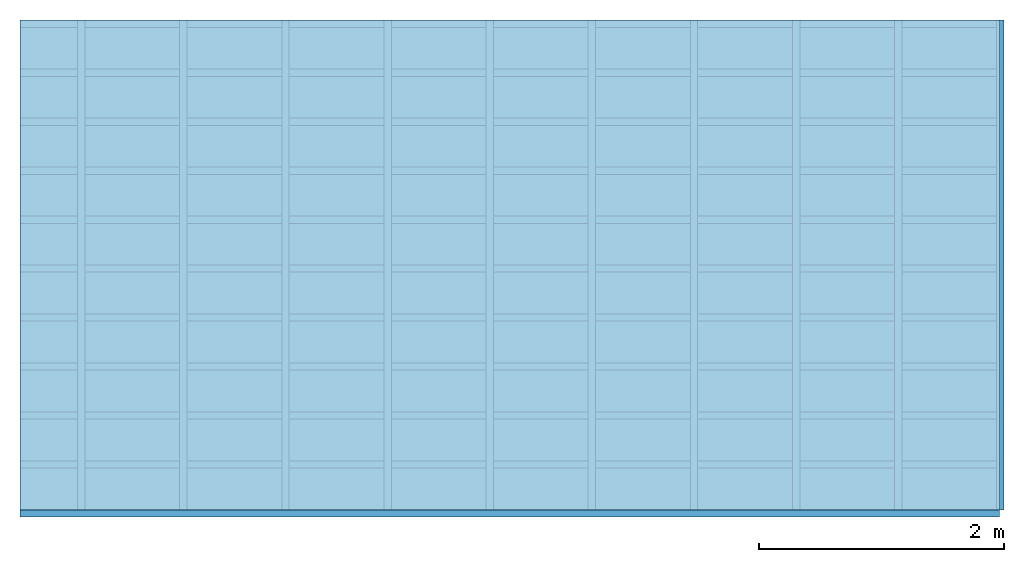
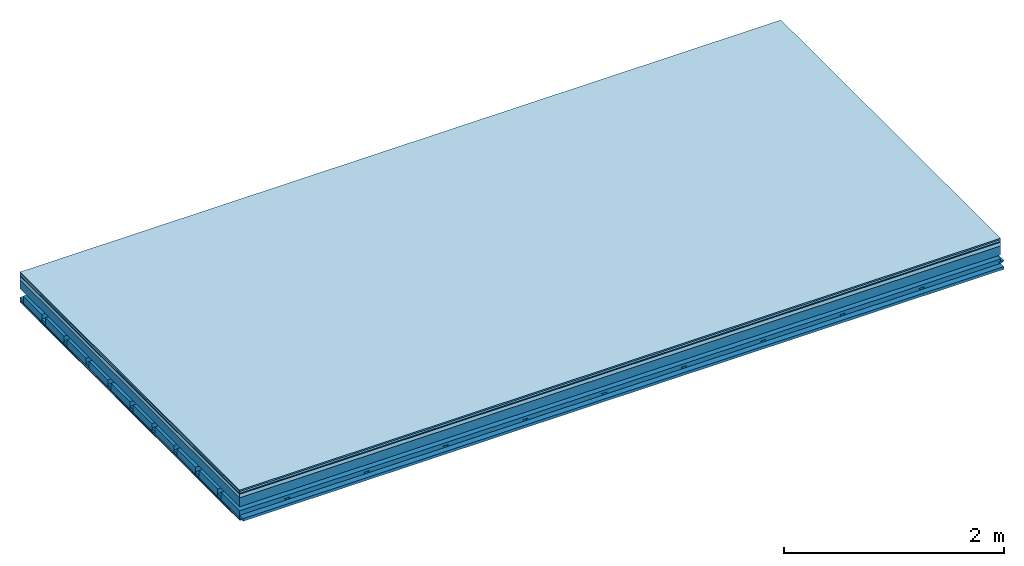
# One storey: 7 plates, 4 members, 1 element without a shape of its own.
"""IFC4 building model written with IfcOpenShell, lengths in metres."""

from ifc_helpers import new_model, si_unit, derived_unit, direction, frame, frame_2d, origin, origin_with_axes, place, context, project, spatial, polyline, rectangle, outline, extrude, material, layer, layer_set, type_object, element, aggregate, save


model = new_model("IFC4")

# Units and contexts
plan_context = context("Plan", 3, precision=1e-05, world=origin(), true_north=direction((0.0, 1.0)))
model_context = context("Model", 3, precision=1e-05, world=origin(), true_north=direction((0.0, 1.0)))
ifc_project = project(units=[si_unit("LENGTHUNIT", "METRE"), derived_unit("SOUNDPRESSUREUNIT", [(si_unit("PRESSUREUNIT", "PASCAL", prefix="MICRO"), 0)]), si_unit("ENERGYUNIT", "JOULE", prefix="MEGA"), si_unit("MASSUNIT", "GRAM", prefix="KILO"), derived_unit("THERMALTRANSMITTANCEUNIT", [(si_unit("POWERUNIT", "WATT"), 1), (si_unit("AREAUNIT", "SQUARE_METRE"), -1), (si_unit("THERMODYNAMICTEMPERATUREUNIT", "KELVIN"), -1)]), derived_unit("AREADENSITYUNIT", [(si_unit("MASSUNIT", "GRAM", prefix="KILO"), 1), (si_unit("AREAUNIT", "SQUARE_METRE"), -1)]), derived_unit("USERDEFINED", [(si_unit("ENERGYUNIT", "JOULE", prefix="MEGA"), 1), (si_unit("AREAUNIT", "SQUARE_METRE"), -1)])], contexts=[plan_context, model_context])

# Site, building, storey
site = spatial("IfcSite", under=ifc_project)
building_placement = place(None, origin())
building = spatial("IfcBuilding", under=site, at=building_placement)
storey_placement = place(building_placement, origin())
storey = spatial("IfcBuildingStorey", under=building, at=storey_placement)

# Slab, members, plates
ifc_material_1 = material(Category="11.013")
ifc_layer_1 = layer(ifc_material_1, 0.015, Name="Flooring")
ifc_material_2 = material(Category="03.007")
ifc_layer_2 = layer(ifc_material_2, 0.02, Name="On-material")
ifc_material_3 = material(Name="Wood fiber generic product", Category="10.009")
ifc_layer_3 = layer(ifc_material_3, 0.01, Name="Impact sound insulation")
ifc_material_4 = material(Name="Concrete panels", Category="02.007")
ifc_layer_4 = layer(ifc_material_4, 0.04, Name="on Supporting structure")
ifc_material_5 = material(Name="no composite action")
ifc_layer_5 = layer(ifc_material_5, 0.0, Name="Bond")
ifc_layer_6 = layer(None, 0.1, Name="Supporting structure")
ifc_layer_7 = layer(ifc_material_5, 0.0, Name="Bond")
ifc_layer_8 = layer(None, 0.095, Name="Coupling")
ifc_layer_9 = layer(None, 0.03, Name="Battens / profiles")
ifc_material_6 = material(Name="Plasterboard type A", Category="03.008")
ifc_layer_10 = layer(ifc_material_6, 0.0125, Name="Ceiling covering 1st layer")
ifc_layer_11 = layer(ifc_material_6, 0.0125, Name="Ceiling covering layer 2")
ifc_material_7 = material(Category="04.001")
ifc_layer_12 = layer(ifc_material_7, 0.003, Name="Surface / treatment")
ifc_layer_set = layer_set([ifc_layer_1, ifc_layer_2, ifc_layer_3, ifc_layer_4, ifc_layer_5, ifc_layer_6, ifc_layer_7, ifc_layer_8, ifc_layer_9, ifc_layer_10, ifc_layer_11, ifc_layer_12])
slab_type = type_object("IfcSlabType", Name="A2131", PredefinedType="NOTDEFINED", material=ifc_layer_set)
slab_placement = place(None, frame((0.0, 0.0, 0.0), z_axis=(0.0, 0.0, -1.0), x_axis=(1.0, 0.0, 0.0)))
slab = element("IfcSlab", 1, at=slab_placement, inside=storey, type_object=slab_type, material=ifc_layer_set, Name="Slab #1")
ifc_material_8 = material(Name="Solid timber panel")
member_1_placement = place(slab_placement, origin())
member_1 = element("IfcMember", 2, at=member_1_placement, material=ifc_material_8, Name="Supporting structure", context=plan_context, shape_type="SweptSolid", body=[
    extrude(rectangle(XDim=1.0, YDim=0.1, at=frame_2d((0.5, 0.05), x_axis=(1.0, 0.0))), frame((0.0, 4.0, 0.085), z_axis=(0.0, -1.0, 0.0), x_axis=(1.0, 0.0, 0.0)), (0.0, 0.0, 1.0), 4.0),
    extrude(rectangle(XDim=1.0, YDim=0.1, at=frame_2d((0.5, 0.05), x_axis=(1.0, 0.0))), frame((1.0, 4.0, 0.085), z_axis=(0.0, -1.0, 0.0), x_axis=(1.0, 0.0, 0.0)), (0.0, 0.0, 1.0), 4.0),
    extrude(rectangle(XDim=1.0, YDim=0.1, at=frame_2d((0.5, 0.05), x_axis=(1.0, 0.0))), frame((2.0, 4.0, 0.085), z_axis=(0.0, -1.0, 0.0), x_axis=(1.0, 0.0, 0.0)), (0.0, 0.0, 1.0), 4.0),
    extrude(rectangle(XDim=1.0, YDim=0.1, at=frame_2d((0.5, 0.05), x_axis=(1.0, 0.0))), frame((3.0, 4.0, 0.085), z_axis=(0.0, -1.0, 0.0), x_axis=(1.0, 0.0, 0.0)), (0.0, 0.0, 1.0), 4.0),
    extrude(rectangle(XDim=1.0, YDim=0.1, at=frame_2d((0.5, 0.05), x_axis=(1.0, 0.0))), frame((4.0, 4.0, 0.085), z_axis=(0.0, -1.0, 0.0), x_axis=(1.0, 0.0, 0.0)), (0.0, 0.0, 1.0), 4.0),
    extrude(rectangle(XDim=1.0, YDim=0.1, at=frame_2d((0.5, 0.05), x_axis=(1.0, 0.0))), frame((5.0, 4.0, 0.085), z_axis=(0.0, -1.0, 0.0), x_axis=(1.0, 0.0, 0.0)), (0.0, 0.0, 1.0), 4.0),
    extrude(rectangle(XDim=1.0, YDim=0.1, at=frame_2d((0.5, 0.05), x_axis=(1.0, 0.0))), frame((6.0, 4.0, 0.085), z_axis=(0.0, -1.0, 0.0), x_axis=(1.0, 0.0, 0.0)), (0.0, 0.0, 1.0), 4.0),
    extrude(rectangle(XDim=1.0, YDim=0.1, at=frame_2d((0.5, 0.05), x_axis=(1.0, 0.0))), frame((7.0, 4.0, 0.085), z_axis=(0.0, -1.0, 0.0), x_axis=(1.0, 0.0, 0.0)), (0.0, 0.0, 1.0), 4.0),
])
ifc_material_9 = material()
member_2_placement = place(slab_placement, origin())
member_2 = element("IfcMember", 3, at=member_2_placement, material=ifc_material_9, Name="Coupling", context=plan_context, shape_type="SweptSolid", body=[
    extrude(outline(polyline([(0.0, 0.0), (0.06, 0.0), (0.04, 0.02), (0.02, 0.02), (0.0, 0.0)])), frame((0.47, 4.0, 0.26), z_axis=(0.0, -1.0, 0.0), x_axis=(1.0, 0.0, 0.0)), (0.0, 0.0, 1.0), 4.0),
    extrude(outline(polyline([(0.0, 0.0), (0.06, 0.0), (0.04, 0.02), (0.02, 0.02), (0.0, 0.0)])), frame((1.304, 4.0, 0.26), z_axis=(0.0, -1.0, 0.0), x_axis=(1.0, 0.0, 0.0)), (0.0, 0.0, 1.0), 4.0),
    extrude(outline(polyline([(0.0, 0.0), (0.06, 0.0), (0.04, 0.02), (0.02, 0.02), (0.0, 0.0)])), frame((2.138, 4.0, 0.26), z_axis=(0.0, -1.0, 0.0), x_axis=(1.0, 0.0, 0.0)), (0.0, 0.0, 1.0), 4.0),
    extrude(outline(polyline([(0.0, 0.0), (0.06, 0.0), (0.04, 0.02), (0.02, 0.02), (0.0, 0.0)])), frame((2.972, 4.0, 0.26), z_axis=(0.0, -1.0, 0.0), x_axis=(1.0, 0.0, 0.0)), (0.0, 0.0, 1.0), 4.0),
    extrude(outline(polyline([(0.0, 0.0), (0.06, 0.0), (0.04, 0.02), (0.02, 0.02), (0.0, 0.0)])), frame((3.806, 4.0, 0.26), z_axis=(0.0, -1.0, 0.0), x_axis=(1.0, 0.0, 0.0)), (0.0, 0.0, 1.0), 4.0),
    extrude(outline(polyline([(0.0, 0.0), (0.06, 0.0), (0.04, 0.02), (0.02, 0.02), (0.0, 0.0)])), frame((4.64, 4.0, 0.26), z_axis=(0.0, -1.0, 0.0), x_axis=(1.0, 0.0, 0.0)), (0.0, 0.0, 1.0), 4.0),
    extrude(outline(polyline([(0.0, 0.0), (0.06, 0.0), (0.04, 0.02), (0.02, 0.02), (0.0, 0.0)])), frame((5.474, 4.0, 0.26), z_axis=(0.0, -1.0, 0.0), x_axis=(1.0, 0.0, 0.0)), (0.0, 0.0, 1.0), 4.0),
    extrude(outline(polyline([(0.0, 0.0), (0.06, 0.0), (0.04, 0.02), (0.02, 0.02), (0.0, 0.0)])), frame((6.308, 4.0, 0.26), z_axis=(0.0, -1.0, 0.0), x_axis=(1.0, 0.0, 0.0)), (0.0, 0.0, 1.0), 4.0),
    extrude(outline(polyline([(0.0, 0.0), (0.06, 0.0), (0.04, 0.02), (0.02, 0.02), (0.0, 0.0)])), frame((7.142, 4.0, 0.26), z_axis=(0.0, -1.0, 0.0), x_axis=(1.0, 0.0, 0.0)), (0.0, 0.0, 1.0), 4.0),
    extrude(outline(polyline([(0.0, 0.0), (0.06, 0.0), (0.04, 0.02), (0.02, 0.02), (0.0, 0.0)])), frame((7.976, 4.0, 0.26), z_axis=(0.0, -1.0, 0.0), x_axis=(1.0, 0.0, 0.0)), (0.0, 0.0, 1.0), 4.0),
])
member_3_placement = place(slab_placement, origin())
member_3 = element("IfcMember", 4, at=member_3_placement, material=ifc_material_9, Name="Battens / profiles", context=plan_context, shape_type="SweptSolid", body=[
    extrude(rectangle(XDim=0.06, YDim=0.03, at=frame_2d((0.03, 0.015), x_axis=(1.0, 0.0))), frame((0.0, 0.0, 0.28), z_axis=(1.0, 0.0, 0.0), x_axis=(0.0, 1.0, 0.0)), (0.0, 0.0, 1.0), 8.0),
    extrude(rectangle(XDim=0.06, YDim=0.03, at=frame_2d((0.03, 0.015), x_axis=(1.0, 0.0))), frame((0.0, 0.4, 0.28), z_axis=(1.0, 0.0, 0.0), x_axis=(0.0, 1.0, 0.0)), (0.0, 0.0, 1.0), 8.0),
    extrude(rectangle(XDim=0.06, YDim=0.03, at=frame_2d((0.03, 0.015), x_axis=(1.0, 0.0))), frame((0.0, 0.8, 0.28), z_axis=(1.0, 0.0, 0.0), x_axis=(0.0, 1.0, 0.0)), (0.0, 0.0, 1.0), 8.0),
    extrude(rectangle(XDim=0.06, YDim=0.03, at=frame_2d((0.03, 0.015), x_axis=(1.0, 0.0))), frame((0.0, 1.2, 0.28), z_axis=(1.0, 0.0, 0.0), x_axis=(0.0, 1.0, 0.0)), (0.0, 0.0, 1.0), 8.0),
    extrude(rectangle(XDim=0.06, YDim=0.03, at=frame_2d((0.03, 0.015), x_axis=(1.0, 0.0))), frame((0.0, 1.6, 0.28), z_axis=(1.0, 0.0, 0.0), x_axis=(0.0, 1.0, 0.0)), (0.0, 0.0, 1.0), 8.0),
    extrude(rectangle(XDim=0.06, YDim=0.03, at=frame_2d((0.03, 0.015), x_axis=(1.0, 0.0))), frame((0.0, 2.0, 0.28), z_axis=(1.0, 0.0, 0.0), x_axis=(0.0, 1.0, 0.0)), (0.0, 0.0, 1.0), 8.0),
    extrude(rectangle(XDim=0.06, YDim=0.03, at=frame_2d((0.03, 0.015), x_axis=(1.0, 0.0))), frame((0.0, 2.4, 0.28), z_axis=(1.0, 0.0, 0.0), x_axis=(0.0, 1.0, 0.0)), (0.0, 0.0, 1.0), 8.0),
    extrude(rectangle(XDim=0.06, YDim=0.03, at=frame_2d((0.03, 0.015), x_axis=(1.0, 0.0))), frame((0.0, 2.8, 0.28), z_axis=(1.0, 0.0, 0.0), x_axis=(0.0, 1.0, 0.0)), (0.0, 0.0, 1.0), 8.0),
    extrude(rectangle(XDim=0.06, YDim=0.03, at=frame_2d((0.03, 0.015), x_axis=(1.0, 0.0))), frame((0.0, 3.2, 0.28), z_axis=(1.0, 0.0, 0.0), x_axis=(0.0, 1.0, 0.0)), (0.0, 0.0, 1.0), 8.0),
    extrude(rectangle(XDim=0.06, YDim=0.03, at=frame_2d((0.03, 0.015), x_axis=(1.0, 0.0))), frame((0.0, 3.6, 0.28), z_axis=(1.0, 0.0, 0.0), x_axis=(0.0, 1.0, 0.0)), (0.0, 0.0, 1.0), 8.0),
    extrude(rectangle(XDim=0.06, YDim=0.03, at=frame_2d((0.03, 0.015), x_axis=(1.0, 0.0))), frame((0.0, 4.0, 0.28), z_axis=(1.0, 0.0, 0.0), x_axis=(0.0, 1.0, 0.0)), (0.0, 0.0, 1.0), 8.0),
])
ifc_material_10 = material()
member_4_placement = place(slab_placement, origin())
member_4 = element("IfcMember", 5, at=member_4_placement, material=ifc_material_10, Name="Cavity", context=plan_context, shape_type="SweptSolid", body=[
    extrude(rectangle(XDim=0.34, YDim=0.08, at=frame_2d((0.17, 0.04), x_axis=(1.0, 0.0))), frame((0.0, 0.06, 0.23), z_axis=(1.0, 0.0, 0.0), x_axis=(0.0, 1.0, 0.0)), (0.0, 0.0, 1.0), 8.0),
    extrude(rectangle(XDim=0.34, YDim=0.08, at=frame_2d((0.17, 0.04), x_axis=(1.0, 0.0))), frame((0.0, 0.46, 0.23), z_axis=(1.0, 0.0, 0.0), x_axis=(0.0, 1.0, 0.0)), (0.0, 0.0, 1.0), 8.0),
    extrude(rectangle(XDim=0.34, YDim=0.08, at=frame_2d((0.17, 0.04), x_axis=(1.0, 0.0))), frame((0.0, 0.86, 0.23), z_axis=(1.0, 0.0, 0.0), x_axis=(0.0, 1.0, 0.0)), (0.0, 0.0, 1.0), 8.0),
    extrude(rectangle(XDim=0.34, YDim=0.08, at=frame_2d((0.17, 0.04), x_axis=(1.0, 0.0))), frame((0.0, 1.26, 0.23), z_axis=(1.0, 0.0, 0.0), x_axis=(0.0, 1.0, 0.0)), (0.0, 0.0, 1.0), 8.0),
    extrude(rectangle(XDim=0.34, YDim=0.08, at=frame_2d((0.17, 0.04), x_axis=(1.0, 0.0))), frame((0.0, 1.66, 0.23), z_axis=(1.0, 0.0, 0.0), x_axis=(0.0, 1.0, 0.0)), (0.0, 0.0, 1.0), 8.0),
    extrude(rectangle(XDim=0.34, YDim=0.08, at=frame_2d((0.17, 0.04), x_axis=(1.0, 0.0))), frame((0.0, 2.06, 0.23), z_axis=(1.0, 0.0, 0.0), x_axis=(0.0, 1.0, 0.0)), (0.0, 0.0, 1.0), 8.0),
    extrude(rectangle(XDim=0.34, YDim=0.08, at=frame_2d((0.17, 0.04), x_axis=(1.0, 0.0))), frame((0.0, 2.46, 0.23), z_axis=(1.0, 0.0, 0.0), x_axis=(0.0, 1.0, 0.0)), (0.0, 0.0, 1.0), 8.0),
    extrude(rectangle(XDim=0.34, YDim=0.08, at=frame_2d((0.17, 0.04), x_axis=(1.0, 0.0))), frame((0.0, 2.86, 0.23), z_axis=(1.0, 0.0, 0.0), x_axis=(0.0, 1.0, 0.0)), (0.0, 0.0, 1.0), 8.0),
    extrude(rectangle(XDim=0.34, YDim=0.08, at=frame_2d((0.17, 0.04), x_axis=(1.0, 0.0))), frame((0.0, 3.26, 0.23), z_axis=(1.0, 0.0, 0.0), x_axis=(0.0, 1.0, 0.0)), (0.0, 0.0, 1.0), 8.0),
    extrude(rectangle(XDim=0.34, YDim=0.08, at=frame_2d((0.17, 0.04), x_axis=(1.0, 0.0))), frame((0.0, 3.66, 0.23), z_axis=(1.0, 0.0, 0.0), x_axis=(0.0, 1.0, 0.0)), (0.0, 0.0, 1.0), 8.0),
])
plate_1_placement = place(slab_placement, origin())
plate_1 = element("IfcPlate", 6, at=plate_1_placement, material=ifc_material_1, Name="Flooring", context=plan_context, shape_type="SweptSolid", body=[
    extrude(rectangle(XDim=8.0, YDim=4.0, at=frame_2d((4.0, 2.0), x_axis=(1.0, 0.0))), origin_with_axes(), (0.0, 0.0, 1.0), 0.015),
])
plate_2_placement = place(slab_placement, origin())
plate_2 = element("IfcPlate", 7, at=plate_2_placement, material=ifc_material_2, Name="On-material", context=plan_context, shape_type="SweptSolid", body=[
    extrude(rectangle(XDim=8.0, YDim=4.0, at=frame_2d((4.0, 2.0), x_axis=(1.0, 0.0))), frame((0.0, 0.0, 0.015), z_axis=(0.0, 0.0, 1.0), x_axis=(1.0, 0.0, 0.0)), (0.0, 0.0, 1.0), 0.02),
])
plate_3_placement = place(slab_placement, origin())
plate_3 = element("IfcPlate", 8, at=plate_3_placement, material=ifc_material_3, Name="Impact sound insulation", context=plan_context, shape_type="SweptSolid", body=[
    extrude(rectangle(XDim=8.0, YDim=4.0, at=frame_2d((4.0, 2.0), x_axis=(1.0, 0.0))), frame((0.0, 0.0, 0.035), z_axis=(0.0, 0.0, 1.0), x_axis=(1.0, 0.0, 0.0)), (0.0, 0.0, 1.0), 0.01),
])
plate_4_placement = place(slab_placement, origin())
plate_4 = element("IfcPlate", 9, at=plate_4_placement, material=ifc_material_4, Name="on Supporting structure", context=plan_context, shape_type="SweptSolid", body=[
    extrude(rectangle(XDim=8.0, YDim=4.0, at=frame_2d((4.0, 2.0), x_axis=(1.0, 0.0))), frame((0.0, 0.0, 0.045), z_axis=(0.0, 0.0, 1.0), x_axis=(1.0, 0.0, 0.0)), (0.0, 0.0, 1.0), 0.04),
])
plate_5_placement = place(slab_placement, origin())
plate_5 = element("IfcPlate", 10, at=plate_5_placement, material=ifc_material_6, Name="Ceiling covering 1st layer", context=plan_context, shape_type="SweptSolid", body=[
    extrude(rectangle(XDim=8.0, YDim=4.0, at=frame_2d((4.0, 2.0), x_axis=(1.0, 0.0))), frame((0.0, 0.0, 0.31), z_axis=(0.0, 0.0, 1.0), x_axis=(1.0, 0.0, 0.0)), (0.0, 0.0, 1.0), 0.0125),
])
plate_6_placement = place(slab_placement, origin())
plate_6 = element("IfcPlate", 11, at=plate_6_placement, material=ifc_material_6, Name="Ceiling covering layer 2", context=plan_context, shape_type="SweptSolid", body=[
    extrude(rectangle(XDim=8.0, YDim=4.0, at=frame_2d((4.0, 2.0), x_axis=(1.0, 0.0))), frame((0.0, 0.0, 0.3225), z_axis=(0.0, 0.0, 1.0), x_axis=(1.0, 0.0, 0.0)), (0.0, 0.0, 1.0), 0.0125),
])
plate_7_placement = place(slab_placement, origin())
plate_7 = element("IfcPlate", 12, at=plate_7_placement, material=ifc_material_7, Name="Surface / treatment", context=plan_context, shape_type="SweptSolid", body=[
    extrude(rectangle(XDim=8.0, YDim=4.0, at=frame_2d((4.0, 2.0), x_axis=(1.0, 0.0))), frame((0.0, 0.0, 0.335), z_axis=(0.0, 0.0, 1.0), x_axis=(1.0, 0.0, 0.0)), (0.0, 0.0, 1.0), 0.003),
])
aggregate(slab, [plate_1, plate_2, plate_3, plate_4, member_1, member_2, member_3, member_4, plate_5, plate_6, plate_7])

save(model, "model.ifc")
